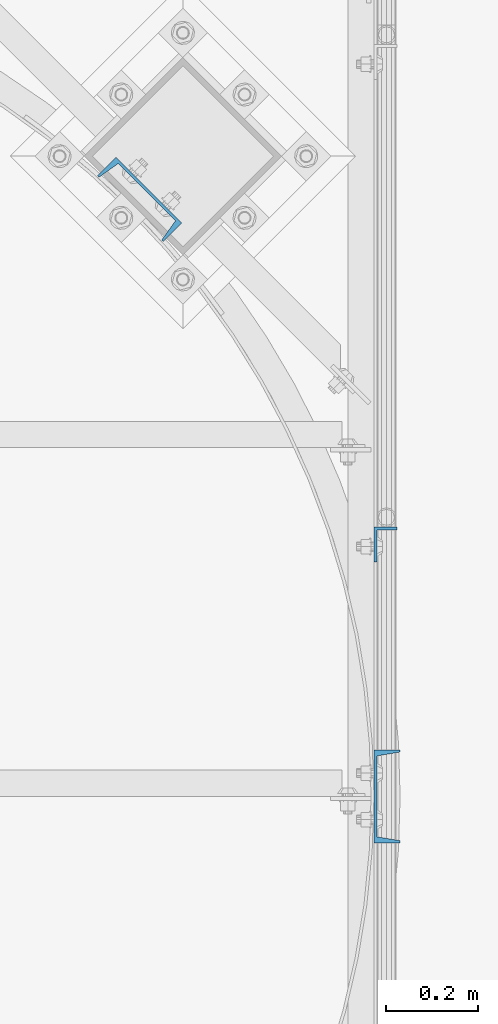
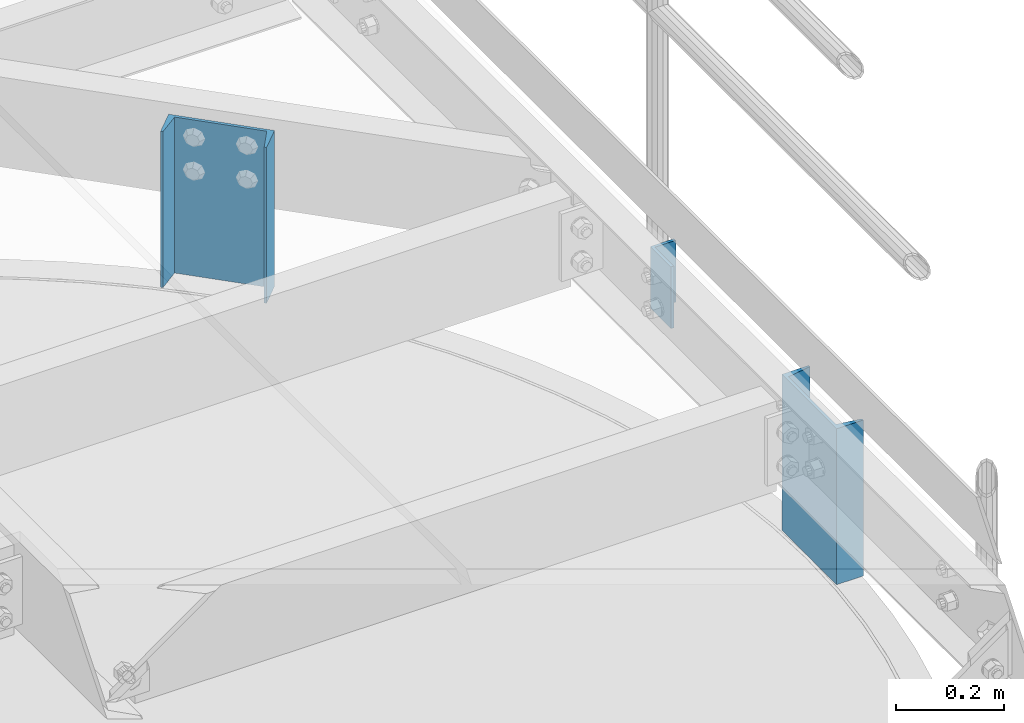
# One storey, part 788 of 1876: 3 columns, 3 elements without a shape of their own.
"""IFC2X3 building model written with IfcOpenShell, lengths in millimetres."""

from ifc_helpers import new_model, si_unit, frame, origin_with_axes, place, context, subcontext, project, spatial, faceted_brep, material, type_object, element, aggregate, save


model = new_model("IFC2X3")

# Units and contexts
model_context = context("Model", 3, precision=1e-05, world=origin_with_axes())
body_context = subcontext(model_context, "Body", "Model", "MODEL_VIEW")
ifc_project = project(units=[si_unit("LENGTHUNIT", "METRE", prefix="MILLI"), si_unit("AREAUNIT", "SQUARE_METRE"), si_unit("VOLUMEUNIT", "CUBIC_METRE"), si_unit("MASSUNIT", "GRAM", prefix="KILO"), si_unit("TIMEUNIT", "SECOND"), si_unit("PLANEANGLEUNIT", "RADIAN"), si_unit("SOLIDANGLEUNIT", "STERADIAN"), si_unit("THERMODYNAMICTEMPERATUREUNIT", "DEGREE_CELSIUS"), si_unit("LUMINOUSINTENSITYUNIT", "LUMEN")], contexts=[model_context])

# Site, building, storey
site_placement = place(None, origin_with_axes())
site = spatial("IfcSite", under=ifc_project, at=site_placement, CompositionType="ELEMENT")
building_placement = place(site_placement, origin_with_axes())
building = spatial("IfcBuilding", under=site, at=building_placement, Name="Undefined", CompositionType="ELEMENT")
storey_placement = place(building_placement, origin_with_axes())
storey = spatial("IfcBuildingStorey", under=building, at=storey_placement, Name="Undefined", CompositionType="ELEMENT", Elevation=0.0)

# Assembly, column
assembly_1_placement = place(storey_placement, origin_with_axes())
assembly_1 = element("IfcElementAssembly", 1, at=assembly_1_placement, inside=storey, Name="HANDRAIL", AssemblyPlace="NOTDEFINED", PredefinedType="RIGID_FRAME")
ifc_material = material(Name="STEEL/A36")
column_type_1 = type_object("IfcColumnType", Name="L3X2X1/4", PredefinedType="NOTDEFINED")
column_1_placement = place(assembly_1_placement, frame((7023.09856849878, -13038.5464042969, 7826.375), z_axis=(0.0, -1.0, 0.0), x_axis=(0.0, 0.0, 1.0)))
column_1 = element("IfcColumn", 2, at=column_1_placement, type_object=column_type_1, material=ifc_material, Name="ANGLE", ObjectType="L3X2X1/4", context=body_context, shape_type="Brep", body=[
    faceted_brep([(0.0, 25.3999999999996, -38.1000000000004), (0.0, 25.3999999999996, 38.1000000000004), (139.7, 25.3999999999996, 38.1000000000004), (139.7, 25.3999999999996, -38.1000000000004), (0.0, 19.0500000000002, 38.1000000000004), (139.7, 19.0500000000002, 38.1000000000004), (0.0, 19.0500000000002, -31.75), (139.7, 19.0500000000002, -31.75), (0.0, -25.3999999999996, -31.75), (139.7, -25.3999999999996, -31.75), (0.0, -25.3999999999996, -38.1000000000004), (139.7, -25.3999999999996, -38.1000000000004)], [[[0, 1, 2, 3]], [[1, 4, 5, 2]], [[4, 6, 7, 5]], [[6, 8, 9, 7]], [[8, 10, 11, 9]], [[10, 0, 3, 11]], [[5, 7, 9, 11, 3, 2]], [[10, 8, 6, 4, 1, 0]]]),
])
aggregate(assembly_1, [column_1])

assembly_2_placement = place(storey_placement, origin_with_axes())
assembly_2 = element("IfcElementAssembly", 3, at=assembly_2_placement, inside=storey, Name="BEAM", AssemblyPlace="NOTDEFINED", PredefinedType="RIGID_FRAME")
column_type_2 = type_object("IfcColumnType", Name="C8X11.5", PredefinedType="NOTDEFINED")
column_2_placement = place(assembly_2_placement, frame((7026.27356849878, -13588.9644287103, 7620.0), z_axis=(0.0, -1.0, 0.0), x_axis=(0.0, 0.0, 1.0)))
column_2 = element("IfcColumn", 4, at=column_2_placement, type_object=column_type_2, material=ifc_material, Name="BEAM", ObjectType="C8X11.5", context=body_context, shape_type="Brep", body=[
    faceted_brep([(0.0, 28.5749999999998, -101.6), (0.0, 28.5749999999998, 101.6), (352.425, 28.5749999999998, 101.6), (352.425, 28.5749999999998, -101.6), (0.0, -28.5749999999998, 101.6), (352.425, -28.5749999999998, 101.6), (0.0, -28.5749999999998, 96.8355950000005), (352.425, -28.5749999999998, 96.8355950000005), (0.0, 22.2250000000004, 88.3723150000005), (352.425, 22.2250000000004, 88.3723150000005), (0.0, 22.2250000000004, -88.3723150000005), (352.425, 22.2250000000004, -88.3723150000005), (0.0, -28.5749999999998, -96.8355950000005), (352.425, -28.5749999999998, -96.8355950000005), (0.0, -28.5749999999998, -101.6), (352.425, -28.5749999999998, -101.6)], [[[0, 1, 2, 3]], [[1, 4, 5, 2]], [[4, 6, 7, 5]], [[6, 8, 9, 7]], [[8, 10, 11, 9]], [[10, 12, 13, 11]], [[12, 14, 15, 13]], [[14, 0, 3, 15]], [[5, 7, 9, 11, 13, 15, 3, 2]], [[14, 12, 10, 8, 6, 4, 1, 0]]]),
])
aggregate(assembly_2, [column_2])

assembly_3_placement = place(storey_placement, origin_with_axes())
assembly_3 = element("IfcElementAssembly", 5, at=assembly_3_placement, inside=storey, Name="BEAM", AssemblyPlace="NOTDEFINED", PredefinedType="RIGID_FRAME")
column_3_placement = place(assembly_3_placement, frame((6485.96330522669, -12284.4724219759, 7620.0), z_axis=(-0.707106781186548, 0.707106781186547, 0.0), x_axis=(0.0, 0.0, 1.0)))
column_3 = element("IfcColumn", 6, at=column_3_placement, type_object=column_type_2, material=ifc_material, Name="BEAM", ObjectType="C8X11.5", context=body_context, shape_type="Brep", body=[
    faceted_brep([(0.0, 28.5749999999998, -101.6), (0.0, 28.5749999999998, 101.6), (352.425, 28.5749999999998, 101.6), (352.425, 28.5749999999998, -101.6), (0.0, -28.5749999999998, 101.6), (352.425, -28.5749999999998, 101.6), (0.0, -28.5749999999998, 96.8355950000005), (352.425, -28.5749999999998, 96.8355950000005), (0.0, 22.2250000000004, 88.3723150000005), (352.425, 22.2250000000004, 88.3723150000005), (0.0, 22.2250000000004, -88.3723150000005), (352.425, 22.2250000000004, -88.3723150000005), (0.0, -28.5749999999998, -96.8355950000005), (352.425, -28.5749999999998, -96.8355950000005), (0.0, -28.5749999999998, -101.6), (352.425, -28.5749999999998, -101.6)], [[[0, 1, 2, 3]], [[1, 4, 5, 2]], [[4, 6, 7, 5]], [[6, 8, 9, 7]], [[8, 10, 11, 9]], [[10, 12, 13, 11]], [[12, 14, 15, 13]], [[14, 0, 3, 15]], [[5, 7, 9, 11, 13, 15, 3, 2]], [[14, 12, 10, 8, 6, 4, 1, 0]]]),
])
aggregate(assembly_3, [column_3])

save(model, "model.ifc")
